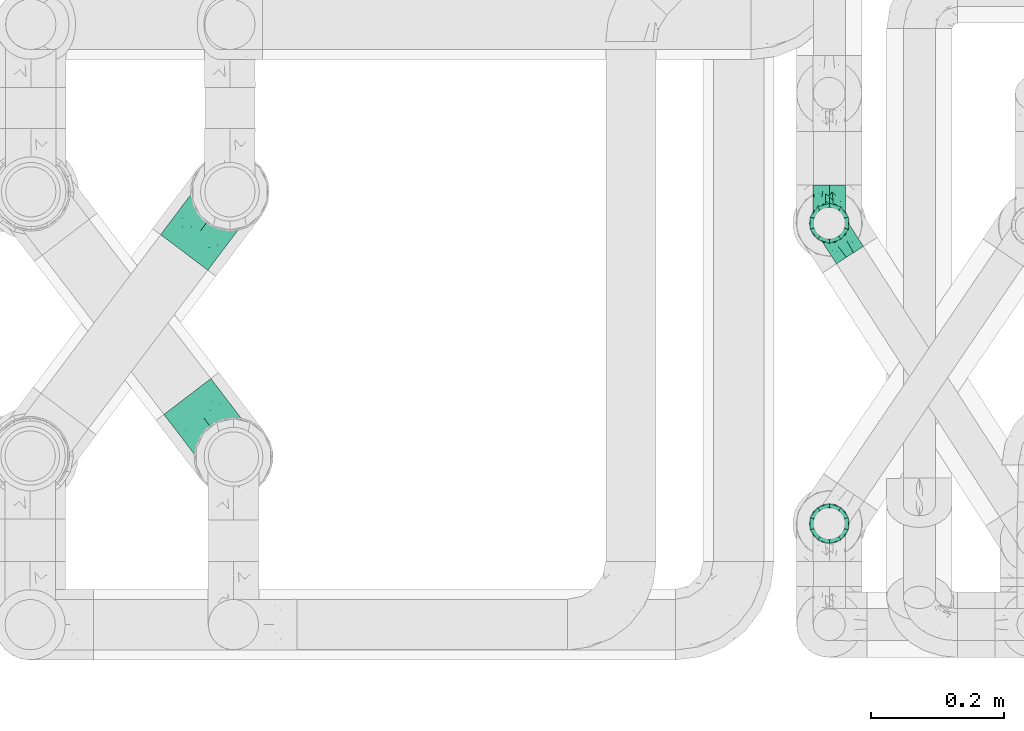
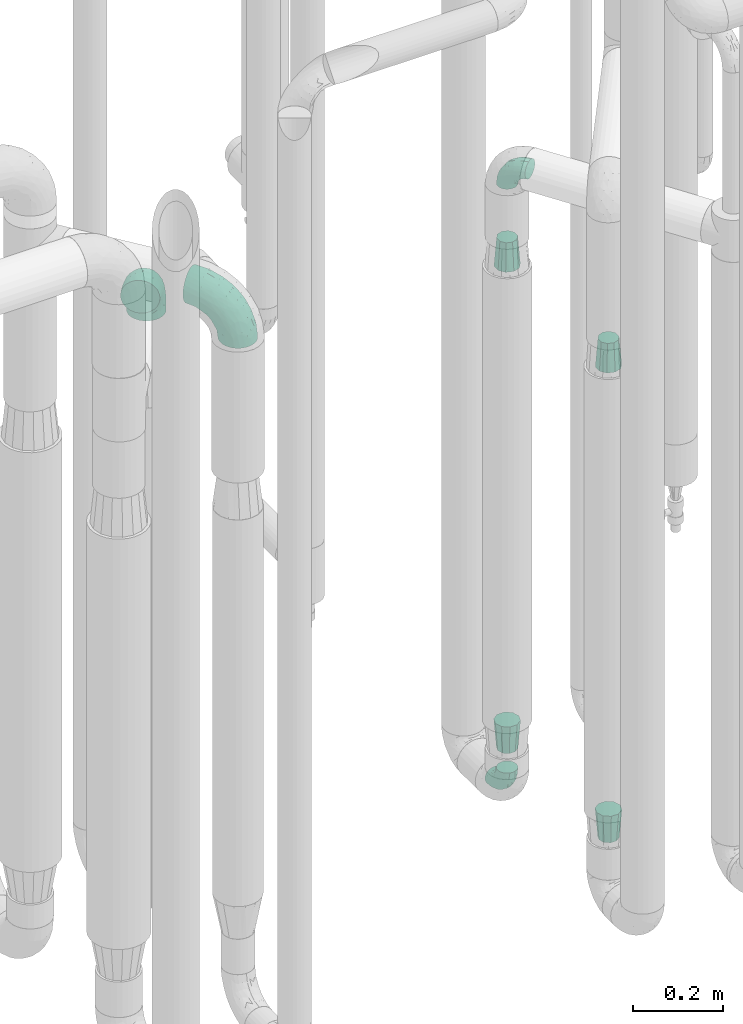
# One storey, part 661 of 827: 8 flow fittings.
"""IFC2X3 building model written with IfcOpenShell, lengths in millimetres."""

from ifc_helpers import new_model, entity, si_unit, converted_unit, derived_unit, direction, frame, origin, place, context, subcontext, project, spatial, faceted_brep, source, transform, mapped, material, type_object, type_shapes, element, save


model = new_model("IFC2X3")

# Units and contexts
model_context = context("Model", 3, precision=0.01, world=origin(), true_north=direction((6.12303176911189e-17, 1.0)))
body_context = subcontext(model_context, "Body", "Model", "MODEL_VIEW")
ifc_project = project(units=[si_unit("LENGTHUNIT", "METRE", prefix="MILLI"), si_unit("AREAUNIT", "SQUARE_METRE"), si_unit("VOLUMEUNIT", "CUBIC_METRE"), converted_unit("PLANEANGLEUNIT", "DEGREE", entity("IfcRatioMeasure", 0.0174532925199433), si_unit("PLANEANGLEUNIT", "RADIAN"), dimensions=[0, 0, 0, 0, 0, 0, 0]), si_unit("MASSUNIT", "GRAM", prefix="KILO"), derived_unit("MASSDENSITYUNIT", [(si_unit("MASSUNIT", "GRAM", prefix="KILO"), 1), (si_unit("LENGTHUNIT", "METRE"), -3)]), derived_unit("MOMENTOFINERTIAUNIT", [(si_unit("LENGTHUNIT", "METRE"), 4)]), si_unit("TIMEUNIT", "SECOND"), si_unit("FREQUENCYUNIT", "HERTZ"), si_unit("THERMODYNAMICTEMPERATUREUNIT", "DEGREE_CELSIUS"), derived_unit("THERMALTRANSMITTANCEUNIT", [(si_unit("MASSUNIT", "GRAM", prefix="KILO"), 1), (si_unit("THERMODYNAMICTEMPERATUREUNIT", "KELVIN"), -1), (si_unit("TIMEUNIT", "SECOND"), -3)]), derived_unit("VOLUMETRICFLOWRATEUNIT", [(si_unit("LENGTHUNIT", "METRE"), 3), (si_unit("TIMEUNIT", "SECOND"), -1)]), derived_unit("MASSFLOWRATEUNIT", [(si_unit("MASSUNIT", "GRAM", prefix="KILO"), 1), (si_unit("TIMEUNIT", "SECOND"), -1)]), derived_unit("ROTATIONALFREQUENCYUNIT", [(si_unit("TIMEUNIT", "SECOND"), -1)]), si_unit("ELECTRICCURRENTUNIT", "AMPERE"), si_unit("ELECTRICVOLTAGEUNIT", "VOLT"), si_unit("POWERUNIT", "WATT"), si_unit("FORCEUNIT", "NEWTON", prefix="KILO"), si_unit("ILLUMINANCEUNIT", "LUX"), si_unit("LUMINOUSFLUXUNIT", "LUMEN"), si_unit("LUMINOUSINTENSITYUNIT", "CANDELA"), derived_unit("USERDEFINED", [(si_unit("MASSUNIT", "GRAM", prefix="KILO"), -1), (si_unit("LENGTHUNIT", "METRE"), -2), (si_unit("TIMEUNIT", "SECOND"), 3), (si_unit("LUMINOUSFLUXUNIT", "LUMEN"), 1)]), derived_unit("LINEARVELOCITYUNIT", [(si_unit("LENGTHUNIT", "METRE"), 1), (si_unit("TIMEUNIT", "SECOND"), -1)]), si_unit("PRESSUREUNIT", "PASCAL"), derived_unit("USERDEFINED", [(si_unit("LENGTHUNIT", "METRE"), -2), (si_unit("MASSUNIT", "GRAM", prefix="KILO"), 1), (si_unit("TIMEUNIT", "SECOND"), -2)]), derived_unit("LINEARFORCEUNIT", [(si_unit("MASSUNIT", "GRAM", prefix="KILO"), 1), (si_unit("LENGTHUNIT", "METRE"), 1), (si_unit("TIMEUNIT", "SECOND"), -2), (si_unit("LENGTHUNIT", "METRE"), -1)]), derived_unit("PLANARFORCEUNIT", [(si_unit("MASSUNIT", "GRAM", prefix="KILO"), 1), (si_unit("LENGTHUNIT", "METRE"), 1), (si_unit("TIMEUNIT", "SECOND"), -2), (si_unit("LENGTHUNIT", "METRE"), -2)])], contexts=[model_context])

# Site, building, storey
site_placement = place(None, origin())
site = spatial("IfcSite", under=ifc_project, at=site_placement, CompositionType="ELEMENT")
building_placement = place(site_placement, origin())
building = spatial("IfcBuilding", under=site, at=building_placement, CompositionType="ELEMENT")
storey_placement = place(building_placement, frame((0.0, 0.0, 28200.0)))
storey = spatial("IfcBuildingStorey", under=building, at=storey_placement, Name="08", CompositionType="ELEMENT", Elevation=28200.0)

# Flow fittings
ifc_material = material()
pipe_fitting_type_1 = type_object("IfcPipeFittingType", Name="ADSK_1", PredefinedType="NOTDEFINED", material=ifc_material)
shared_shape_1 = source(origin(), body_context, "Body", "Brep", [
    faceted_brep([(-57.0, 12.07, -20.91), (-57.0, 6.25, -23.33), (-57.0, 0.0, -24.15), (-57.0, -6.25, -23.33), (-57.0, -12.08, -20.91), (-57.0, -17.08, -17.08), (-57.0, -20.91, -12.08), (-57.0, -23.33, -6.25), (-57.0, -24.15, 0.0), (-57.0, -23.33, 6.25), (-57.0, -20.91, 12.07), (-57.0, -17.08, 17.08), (-57.0, -12.08, 20.91), (-57.0, -6.25, 23.33), (-57.0, 0.0, 24.15), (-57.0, 6.25, 23.33), (-57.0, 12.07, 20.91), (-57.0, 17.08, 17.08), (-57.0, 20.91, 12.07), (-57.0, 23.33, 6.25), (-57.0, 24.15, 0.0), (-57.0, 23.33, -6.25), (-57.0, 20.91, -12.08), (-57.0, 17.08, -17.08), (0.0, 57.0, -24.15), (-6.25, 57.0, -23.33), (-12.07, 57.0, -20.91), (-17.08, 57.0, -17.08), (-20.91, 57.0, -12.08), (-23.33, 57.0, -6.25), (-24.15, 57.0, 0.0), (-23.33, 57.0, 6.25), (-20.91, 57.0, 12.07), (-17.08, 57.0, 17.08), (-12.07, 57.0, 20.91), (-6.25, 57.0, 23.33), (0.0, 57.0, 24.15), (6.25, 57.0, 23.33), (12.08, 57.0, 20.91), (17.08, 57.0, 17.08), (20.91, 57.0, 12.07), (23.33, 57.0, 6.25), (24.15, 57.0, 0.0), (23.33, 57.0, -6.25), (20.91, 57.0, -12.08), (17.08, 57.0, -17.08), (12.08, 57.0, -20.91), (6.25, 57.0, -23.33), (14.9, 21.14, 6.17), (13.61, 24.64, 12.48), (6.23, 8.95, 8.98), (-41.47, -21.06, 0.0), (-41.92, -18.38, 13.72), (-24.64, -13.61, 12.48), (-37.37, -13.24, 18.15), (-6.8, -4.93, 8.18), (-21.76, -15.19, 6.22), (-12.78, -9.18, 0.0), (-37.73, -20.51, 7.75), (-7.38, 7.38, 20.24), (-23.37, -4.26, 20.42), (-11.9, -3.19, 15.86), (-42.14, -8.7, 21.82), (13.24, 37.37, 18.15), (9.33, 23.53, 16.85), (4.26, 23.37, 20.42), (2.77, 10.92, 15.55), (-29.46, 0.91, 23.52), (-44.13, 20.56, 15.69), (-39.25, 26.33, 10.88), (-49.02, 22.92, 9.96), (-34.58, 23.87, 17.15), (-15.8, 6.8, 22.81), (-8.67, 20.47, 23.88), (-18.12, 12.9, 24.08), (-48.29, 14.92, 19.65), (-44.06, -2.85, 23.78), (-9.23, 48.95, 22.58), (-3.78, 42.74, 24.07), (-40.34, 4.26, 24.09), (-44.02, 26.14, 5.46), (-44.04, 9.88, 22.74), (-4.95, 16.87, 22.52), (-2.75, 1.43, 12.5), (-25.48, 40.98, 10.71), (20.51, 37.73, 7.75), (18.38, 41.92, 13.72), (8.7, 42.14, 21.82), (-25.95, -17.97, 0.0), (2.85, 44.06, 23.78), (21.06, 41.47, 0.0), (17.97, 25.95, 0.0), (-24.04, -9.27, 17.13), (-33.26, 33.26, 5.86), (-28.55, 40.57, 0.0), (-40.57, 28.55, 0.0), (-25.29, 47.19, 4.06), (-27.01, 31.1, 16.77), (-15.7, 43.95, 19.9), (-20.27, 45.22, 15.61), (-30.53, 31.98, 12.64), (-11.28, 38.33, 22.92), (-9.97, 27.88, 24.09), (-20.15, 30.26, 21.25), (-31.25, 11.75, 23.64), (-28.75, 7.23, 24.15), (-29.53, 18.06, 22.27), (-28.44, 24.21, 20.02), (-37.55, 17.7, 20.26), (-15.88, 29.25, 22.99), (-20.82, 20.82, 23.44), (-0.91, 29.46, 23.52), (-13.5, -7.67, 12.04), (1.49, 1.56, 5.16), (8.86, 10.35, 4.59), (0.38, -0.38, 0.0), (9.18, 12.78, 0.0), (-37.37, -13.24, -18.15), (8.86, 10.35, -4.59), (-45.22, 20.27, -15.61), (-43.95, 15.7, -19.9), (-38.33, 11.28, -22.92), (-48.95, 9.23, -22.58), (-47.19, 25.29, -4.06), (-33.26, 33.26, -5.86), (18.38, 41.92, -13.72), (-30.26, 20.15, -21.25), (2.85, 44.06, -23.78), (-4.26, 40.34, -24.09), (-40.98, 25.48, -10.71), (-41.92, -18.38, -13.72), (9.25, 23.5, -16.92), (4.26, 23.37, -20.42), (13.24, 37.37, -18.15), (-37.73, -20.51, -7.75), (-11.75, 31.25, -23.64), (-7.23, 28.75, -24.15), (-12.9, 18.12, -24.08), (8.7, 42.14, -21.82), (-44.06, -2.85, -23.78), (-6.8, 15.8, -22.81), (-20.47, 8.67, -23.88), (-24.64, -13.61, -12.48), (-42.74, 3.78, -24.07), (-18.06, 29.53, -22.27), (-24.21, 28.44, -20.02), (-27.88, 9.97, -24.09), (-31.1, 27.01, -16.77), (-26.14, 44.02, -5.46), (14.9, 21.14, -6.17), (20.51, 37.73, -7.75), (-9.88, 44.04, -22.74), (-20.56, 44.13, -15.69), (-21.76, -15.19, -6.22), (-13.5, -7.67, -12.04), (-24.14, -9.76, -16.74), (-11.9, -3.19, -15.86), (-14.92, 48.29, -19.65), (-23.37, -4.26, -20.42), (-0.91, 29.46, -23.52), (-26.33, 39.25, -10.88), (-23.87, 34.58, -17.15), (-42.14, -8.7, -21.82), (-22.92, 49.02, -9.96), (13.61, 24.64, -12.48), (-31.98, 30.53, -12.64), (-16.87, 4.95, -22.52), (-17.7, 37.55, -20.26), (-29.25, 15.88, -22.99), (-20.82, 20.82, -23.44), (-29.46, 0.91, -23.52), (-7.38, 7.38, -20.24), (2.77, 10.92, -15.55), (6.23, 8.95, -8.98), (-6.8, -4.93, -8.18), (-2.81, 1.41, -12.54), (1.49, 1.56, -5.16)], [[[0, 1, 2, 3, 4, 5, 6, 7, 8, 9, 10, 11, 12, 13, 14, 15, 16, 17, 18, 19, 20, 21, 22, 23]], [[24, 25, 26, 27, 28, 29, 30, 31, 32, 33, 34, 35, 36, 37, 38, 39, 40, 41, 42, 43, 44, 45, 46, 47]], [[48, 49, 50]], [[9, 8, 51]], [[52, 53, 54]], [[55, 56, 57]], [[10, 58, 52]], [[9, 58, 10]], [[59, 60, 61]], [[54, 12, 11]], [[54, 62, 12]], [[63, 39, 38]], [[64, 65, 66]], [[62, 60, 67]], [[68, 69, 70]], [[71, 69, 68]], [[72, 73, 74]], [[16, 75, 17]], [[13, 76, 14]], [[35, 77, 78]], [[14, 79, 15]], [[17, 68, 18]], [[14, 76, 79]], [[20, 19, 80]], [[70, 19, 18]], [[81, 15, 79]], [[15, 81, 16]], [[73, 72, 82]], [[66, 83, 50]], [[32, 31, 84]], [[85, 86, 49]], [[63, 87, 65]], [[56, 58, 88]], [[36, 89, 37]], [[85, 41, 40]], [[36, 35, 78]], [[90, 41, 85]], [[40, 39, 86]], [[12, 62, 13]], [[86, 85, 40]], [[48, 85, 49]], [[85, 91, 90]], [[87, 38, 37]], [[92, 60, 54]], [[80, 69, 93]], [[93, 94, 95]], [[10, 52, 11]], [[94, 96, 30]], [[97, 98, 99]], [[80, 93, 95]], [[100, 97, 84]], [[99, 98, 33]], [[101, 102, 78]], [[103, 101, 98]], [[96, 31, 30]], [[77, 98, 101]], [[77, 35, 34]], [[34, 33, 98]], [[9, 51, 58]], [[87, 63, 38]], [[104, 105, 74]], [[106, 103, 107]], [[106, 81, 104]], [[75, 68, 17]], [[108, 107, 71]], [[33, 32, 99]], [[109, 103, 110]], [[101, 109, 102]], [[89, 78, 111]], [[53, 52, 58]], [[54, 11, 52]], [[60, 62, 54]], [[88, 58, 51]], [[76, 62, 67]], [[53, 112, 92]], [[60, 59, 72]], [[39, 63, 86]], [[49, 86, 63]], [[89, 87, 37]], [[42, 41, 90]], [[111, 82, 65]], [[111, 65, 87]], [[65, 59, 66]], [[104, 81, 79]], [[75, 81, 108]], [[32, 84, 99]], [[97, 99, 84]], [[98, 97, 103]], [[106, 107, 108]], [[74, 102, 110]], [[111, 78, 102]], [[74, 110, 104]], [[74, 67, 72]], [[61, 92, 112]], [[66, 59, 61]], [[56, 53, 58]], [[66, 50, 49]], [[61, 112, 83]], [[66, 49, 64]], [[78, 89, 36]], [[87, 89, 111]], [[62, 76, 13]], [[79, 76, 67]], [[100, 93, 69]], [[96, 93, 84]], [[55, 113, 50]], [[113, 114, 50]], [[104, 79, 105]], [[106, 104, 110]], [[20, 80, 95]], [[85, 48, 91]], [[115, 114, 113]], [[116, 91, 48]], [[70, 80, 19]], [[93, 96, 94]], [[84, 31, 96]], [[103, 106, 110]], [[81, 106, 108]], [[103, 97, 107]], [[71, 107, 97]], [[71, 97, 100]], [[108, 71, 68]], [[79, 67, 105]], [[67, 74, 105]], [[115, 113, 57]], [[112, 56, 55]], [[56, 88, 57]], [[60, 72, 67]], [[82, 72, 59]], [[65, 82, 59]], [[82, 111, 73]], [[111, 102, 73]], [[102, 74, 73]], [[81, 75, 16]], [[68, 75, 108]], [[68, 70, 18]], [[80, 70, 69]], [[98, 77, 34]], [[78, 77, 101]], [[93, 100, 84]], [[71, 100, 69]], [[102, 109, 110]], [[101, 103, 109]], [[53, 92, 54]], [[61, 60, 92]], [[56, 112, 53]], [[83, 112, 55]], [[50, 83, 55]], [[61, 83, 66]], [[49, 63, 64]], [[65, 64, 63]], [[57, 113, 55]], [[114, 115, 116]], [[116, 48, 114]], [[48, 50, 114]], [[117, 5, 4]], [[116, 115, 118]], [[119, 120, 23]], [[121, 122, 120]], [[95, 123, 20]], [[0, 23, 120]], [[124, 95, 94]], [[125, 45, 44]], [[121, 120, 126]], [[24, 127, 128]], [[22, 21, 129]], [[0, 122, 1]], [[5, 117, 130]], [[131, 132, 133]], [[134, 88, 51]], [[135, 136, 137]], [[6, 5, 130]], [[46, 138, 47]], [[139, 3, 2]], [[140, 141, 137]], [[6, 134, 7]], [[134, 130, 142]], [[143, 2, 1]], [[144, 126, 145]], [[121, 146, 143]], [[147, 120, 119]], [[94, 148, 124]], [[149, 150, 91]], [[30, 29, 148]], [[151, 25, 128]], [[27, 152, 28]], [[134, 153, 88]], [[154, 155, 156]], [[27, 26, 157]], [[151, 26, 25]], [[155, 158, 156]], [[24, 47, 127]], [[1, 122, 143]], [[138, 132, 159]], [[160, 152, 161]], [[24, 128, 25]], [[46, 133, 138]], [[162, 117, 4]], [[148, 160, 124]], [[152, 160, 163]], [[154, 142, 155]], [[45, 125, 133]], [[133, 46, 45]], [[125, 164, 133]], [[51, 7, 134]], [[42, 90, 43]], [[165, 147, 129]], [[153, 134, 142]], [[43, 150, 44]], [[162, 4, 3]], [[141, 140, 166]], [[117, 162, 158]], [[163, 29, 28]], [[43, 90, 150]], [[123, 21, 20]], [[144, 151, 135]], [[157, 152, 27]], [[167, 145, 161]], [[23, 22, 119]], [[168, 126, 169]], [[121, 168, 146]], [[139, 143, 170]], [[142, 130, 117]], [[8, 7, 51]], [[134, 6, 130]], [[139, 162, 3]], [[170, 166, 158]], [[170, 158, 162]], [[158, 171, 156]], [[44, 150, 125]], [[91, 150, 90]], [[164, 125, 150]], [[132, 138, 133]], [[127, 138, 159]], [[131, 164, 172]], [[132, 171, 140]], [[135, 151, 128]], [[157, 151, 167]], [[22, 129, 119]], [[147, 119, 129]], [[120, 147, 126]], [[144, 145, 167]], [[137, 146, 169]], [[170, 143, 146]], [[137, 169, 135]], [[137, 159, 140]], [[171, 172, 156]], [[173, 174, 175]], [[156, 175, 154]], [[174, 57, 153]], [[132, 172, 171]], [[172, 164, 173]], [[143, 139, 2]], [[162, 139, 170]], [[138, 127, 47]], [[128, 127, 159]], [[165, 124, 160]], [[123, 124, 129]], [[149, 173, 164]], [[176, 174, 173]], [[135, 128, 136]], [[144, 135, 169]], [[150, 149, 164]], [[176, 118, 115]], [[149, 91, 116]], [[30, 148, 94]], [[163, 148, 29]], [[124, 123, 95]], [[129, 21, 123]], [[126, 144, 169]], [[151, 144, 167]], [[126, 147, 145]], [[161, 145, 147]], [[161, 147, 165]], [[167, 161, 152]], [[128, 159, 136]], [[159, 137, 136]], [[154, 153, 142]], [[132, 140, 159]], [[174, 176, 57]], [[57, 88, 153]], [[166, 140, 171]], [[158, 166, 171]], [[166, 170, 141]], [[170, 146, 141]], [[146, 137, 141]], [[151, 157, 26]], [[152, 157, 167]], [[152, 163, 28]], [[148, 163, 160]], [[120, 122, 0]], [[143, 122, 121]], [[124, 165, 129]], [[161, 165, 160]], [[146, 168, 169]], [[121, 126, 168]], [[142, 117, 155]], [[158, 155, 117]], [[175, 156, 172]], [[153, 154, 174]], [[173, 175, 172]], [[174, 154, 175]], [[164, 131, 133]], [[172, 132, 131]], [[176, 173, 118]], [[57, 176, 115]], [[173, 149, 118]], [[149, 116, 118]]]),
])
type_shapes(pipe_fitting_type_1, [shared_shape_1])
for number, where, z_axis, x_axis, name in (
    (1, (46692.79, 14239.53, 2100.11), (0.839206573460925, 0.543812768386302, 0.0), (0.0, 0.0, 1.0), "ADSK_1"),
    (2, (46692.79, 14239.53, 400.0), (-1.0, 0.0, 0.0), (0.0, -1.0, 0.0), "ADSK_1"),
):
    element("IfcFlowFitting", number, at=place(storey_placement, frame(where, z_axis=z_axis, x_axis=x_axis)), inside=storey, type_object=pipe_fitting_type_1, material=ifc_material, Name=name, ObjectType="ADSK_1", context=body_context, shape_type="MappedRepresentation", body=[
        mapped(shared_shape_1, transform((0.0, 0.0, 0.0), scale=1.0)),
    ])
pipe_fitting_type_2 = type_object("IfcPipeFittingType", Name="ADSK_1", PredefinedType="NOTDEFINED", material=ifc_material)
shared_shape_2 = source(origin(), body_context, "Body", "Brep", [
    faceted_brep([(-114.0, 22.22, -38.49), (-114.0, 11.5, -42.94), (-114.0, 0.0, -44.45), (-114.0, -11.5, -42.94), (-114.0, -22.23, -38.49), (-114.0, -31.43, -31.43), (-114.0, -38.49, -22.23), (-114.0, -42.94, -11.5), (-114.0, -44.45, 0.0), (-114.0, -42.94, 11.5), (-114.0, -38.49, 22.22), (-114.0, -31.43, 31.43), (-114.0, -22.23, 38.49), (-114.0, -11.5, 42.94), (-114.0, 0.0, 44.45), (-114.0, 11.5, 42.94), (-114.0, 22.22, 38.49), (-114.0, 31.43, 31.43), (-114.0, 38.49, 22.22), (-114.0, 42.94, 11.5), (-114.0, 44.45, 0.0), (-114.0, 42.94, -11.5), (-114.0, 38.49, -22.23), (-114.0, 31.43, -31.43), (0.0, 114.0, -44.45), (-11.5, 114.0, -42.94), (-22.22, 114.0, -38.49), (-31.43, 114.0, -31.43), (-38.49, 114.0, -22.23), (-42.94, 114.0, -11.5), (-44.45, 114.0, 0.0), (-42.94, 114.0, 11.5), (-38.49, 114.0, 22.22), (-31.43, 114.0, 31.43), (-22.22, 114.0, 38.49), (-11.5, 114.0, 42.94), (0.0, 114.0, 44.45), (11.5, 114.0, 42.94), (22.23, 114.0, 38.49), (31.43, 114.0, 31.43), (38.49, 114.0, 22.22), (42.94, 114.0, 11.5), (44.45, 114.0, 0.0), (42.94, 114.0, -11.5), (38.49, 114.0, -22.23), (31.43, 114.0, -31.43), (22.23, 114.0, -38.49), (11.5, 114.0, -42.94), (-24.5, -15.82, 8.24), (-7.18, -2.06, 7.97), (-13.53, -4.79, 15.72), (-92.03, -41.56, 0.0), (-77.08, -37.56, 14.57), (23.74, 74.96, 33.55), (-72.99, -39.05, 0.0), (-84.56, -15.6, 40.23), (-47.88, -6.37, 37.83), (-59.8, 2.77, 43.37), (-84.46, -33.54, 25.41), (16.69, 49.28, 31.02), (6.37, 47.88, 37.83), (3.35, 25.47, 29.77), (-47.43, 81.55, 19.51), (-74.96, -23.74, 33.55), (-46.77, -27.89, 11.23), (-53.88, -31.14, 0.0), (-87.05, 38.52, 28.81), (-63.44, 55.78, 24.79), (-93.24, 43.37, 18.58), (-16.67, 16.67, 37.64), (-25.47, -3.35, 29.77), (-17.2, 97.7, 41.53), (-7.42, 85.54, 44.3), (-67.09, 46.29, 31.23), (-18.08, 42.1, 44.06), (-32.93, 14.9, 42.17), (-11.54, 34.94, 41.69), (-95.7, 27.79, 36.14), (-88.55, -4.92, 43.79), (-2.77, 59.8, 43.37), (-87.65, 48.44, 9.87), (-81.01, 8.37, 44.32), (-37.63, 90.26, 28.6), (-51.29, 61.56, 30.59), (-29.32, 87.72, 36.52), (23.49, 49.5, 23.28), (8.19, 20.11, 19.18), (-70.06, 58.9, 9.01), (-87.38, 49.74, 0.0), (-88.15, 18.57, 41.8), (-7.96, 6.22, 24.33), (33.54, 84.46, 25.41), (37.56, 77.08, 14.57), (-58.37, 34.98, 40.92), (-62.38, 23.02, 43.45), (24.15, 39.93, 12.16), (31.14, 53.88, 0.0), (-58.13, 14.61, 44.45), (-37.17, 26.09, 44.37), (4.92, 88.55, 43.79), (-34.77, -23.22, 0.0), (-49.5, -23.49, 23.28), (41.56, 92.03, 0.0), (-57.83, 66.03, 19.12), (-71.84, 54.46, 17.06), (-46.46, 94.23, 8.51), (-49.74, 87.38, 0.0), (-38.96, 59.98, 38.88), (-55.29, 46.95, 36.83), (-64.82, 64.82, 0.0), (-55.88, 73.75, 10.01), (15.6, 84.56, 40.23), (-21.6, 76.38, 42.11), (-49.04, -15.53, 31.95), (-19.97, 55.59, 44.33), (-73.61, 33.95, 37.2), (-31.05, 58.14, 42.19), (-41.3, 41.3, 43.02), (-27.36, -11.22, 22.61), (9.28, 15.84, 8.73), (23.22, 34.77, 0.0), (39.05, 72.99, 0.0), (-1.96, 1.96, 0.0), (10.63, 18.37, 0.0), (-18.37, -10.63, 0.0), (-97.7, 17.2, -41.53), (9.28, 15.84, -8.73), (-13.53, -4.79, -15.72), (8.19, 20.11, -19.18), (-85.54, 7.42, -44.3), (-8.37, 81.01, -44.32), (-90.26, 37.63, -28.6), (-87.72, 29.32, -36.52), (-27.79, 95.7, -36.14), (-38.52, 87.05, -28.81), (-94.23, 46.46, -8.51), (-84.56, -15.6, -40.23), (-73.75, 55.88, -10.01), (-10.19, -4.86, -7.51), (-76.38, 21.6, -42.11), (-59.98, 38.96, -38.88), (-49.28, -16.69, -31.02), (-47.88, -6.37, -37.83), (-25.47, -3.35, -29.77), (-34.98, 58.37, -40.92), (-46.95, 55.29, -36.83), (-77.08, -37.56, -14.57), (-18.57, 88.15, -41.8), (-23.02, 62.38, -43.45), (-55.78, 63.44, -24.79), (-43.37, 93.24, -18.58), (-84.46, -33.54, -25.41), (-33.95, 73.61, -37.2), (-46.29, 67.09, -31.23), (-74.96, -23.74, -33.55), (-48.44, 87.65, -9.87), (-45.44, -27.06, -11.87), (-88.55, -4.92, -43.79), (-49.5, -23.49, -23.28), (-14.61, 58.13, -44.45), (-26.09, 37.17, -44.37), (15.6, 84.56, -40.23), (6.37, 47.88, -37.83), (-2.77, 59.8, -43.37), (-81.55, 47.43, -19.51), (33.54, 84.46, -25.41), (23.49, 49.5, -23.28), (23.74, 74.96, -33.55), (-42.1, 18.08, -44.06), (-14.9, 32.93, -42.17), (-34.94, 11.54, -41.69), (-61.56, 51.29, -30.59), (-27.36, -11.22, -22.61), (37.56, 77.08, -14.57), (4.92, 88.55, -43.79), (-59.8, 2.77, -43.37), (-66.03, 57.83, -19.12), (-54.46, 71.84, -17.06), (-55.59, 19.97, -44.33), (-58.9, 70.06, -9.01), (24.15, 39.93, -12.16), (15.53, 49.04, -31.95), (-58.14, 31.05, -42.19), (-41.3, 41.3, -43.02), (-16.67, 16.67, -37.64), (3.35, 25.47, -29.77), (-7.96, 6.22, -24.33), (-26.36, -16.33, -11.05)], [[[0, 1, 2, 3, 4, 5, 6, 7, 8, 9, 10, 11, 12, 13, 14, 15, 16, 17, 18, 19, 20, 21, 22, 23]], [[24, 25, 26, 27, 28, 29, 30, 31, 32, 33, 34, 35, 36, 37, 38, 39, 40, 41, 42, 43, 44, 45, 46, 47]], [[48, 49, 50]], [[51, 52, 9]], [[53, 39, 38]], [[9, 52, 10]], [[54, 52, 51]], [[55, 56, 57]], [[11, 10, 58]], [[59, 60, 61]], [[32, 31, 62]], [[63, 12, 11]], [[63, 55, 12]], [[64, 52, 65]], [[66, 67, 68]], [[69, 56, 70]], [[35, 71, 72]], [[67, 66, 73]], [[74, 75, 76]], [[16, 77, 17]], [[13, 78, 14]], [[76, 79, 74]], [[68, 80, 19]], [[18, 17, 66]], [[14, 78, 81]], [[20, 19, 80]], [[82, 83, 84]], [[85, 61, 86]], [[87, 88, 80]], [[18, 68, 19]], [[15, 89, 16]], [[14, 81, 15]], [[70, 90, 61]], [[17, 77, 66]], [[91, 85, 92]], [[93, 89, 94]], [[95, 96, 92]], [[84, 71, 34]], [[94, 97, 98]], [[37, 36, 99]], [[40, 39, 91]], [[40, 92, 41]], [[65, 100, 64]], [[91, 92, 40]], [[58, 101, 63]], [[92, 102, 41]], [[92, 85, 95]], [[67, 103, 104]], [[34, 33, 84]], [[105, 62, 31]], [[52, 58, 10]], [[106, 105, 30]], [[93, 107, 108]], [[106, 109, 110]], [[53, 111, 60]], [[84, 112, 71]], [[84, 107, 112]], [[33, 82, 84]], [[12, 55, 13]], [[113, 56, 63]], [[111, 38, 37]], [[34, 71, 35]], [[36, 35, 72]], [[112, 114, 72]], [[110, 105, 106]], [[111, 53, 38]], [[115, 108, 73]], [[89, 15, 81]], [[104, 87, 80]], [[110, 87, 103]], [[33, 32, 82]], [[116, 107, 117]], [[112, 116, 114]], [[99, 72, 79]], [[56, 55, 63]], [[78, 55, 57]], [[101, 118, 113]], [[56, 69, 75]], [[99, 111, 37]], [[79, 76, 60]], [[79, 60, 111]], [[60, 69, 61]], [[101, 58, 52]], [[63, 11, 58]], [[39, 53, 91]], [[85, 91, 53]], [[94, 89, 81]], [[77, 89, 115]], [[84, 83, 107]], [[93, 108, 115]], [[98, 114, 117]], [[79, 72, 114]], [[98, 117, 94]], [[98, 57, 75]], [[32, 62, 82]], [[83, 82, 62]], [[70, 113, 118]], [[61, 85, 59]], [[48, 64, 100]], [[95, 119, 120]], [[69, 70, 61]], [[70, 118, 90]], [[72, 99, 36]], [[111, 99, 79]], [[55, 78, 13]], [[81, 78, 57]], [[94, 81, 97]], [[93, 94, 117]], [[66, 68, 18]], [[80, 68, 104]], [[103, 87, 104]], [[80, 88, 20]], [[50, 49, 119]], [[95, 85, 86]], [[119, 95, 86]], [[121, 92, 96]], [[50, 119, 86]], [[119, 122, 123, 120]], [[110, 109, 87]], [[88, 87, 109]], [[62, 105, 110]], [[30, 105, 31]], [[81, 57, 97]], [[57, 98, 97]], [[107, 93, 117]], [[89, 93, 115]], [[107, 83, 108]], [[73, 108, 83]], [[67, 73, 83]], [[115, 73, 66]], [[103, 83, 62]], [[67, 104, 68]], [[83, 103, 67]], [[110, 103, 62]], [[89, 77, 16]], [[66, 77, 115]], [[56, 75, 57]], [[76, 75, 69]], [[60, 76, 69]], [[79, 114, 74]], [[114, 98, 74]], [[75, 74, 98]], [[9, 8, 51]], [[102, 92, 121]], [[102, 42, 41]], [[72, 71, 112]], [[52, 54, 65]], [[64, 48, 118]], [[101, 52, 64]], [[124, 122, 49]], [[118, 48, 50]], [[49, 48, 124]], [[119, 49, 122]], [[48, 100, 124]], [[114, 116, 117]], [[112, 107, 116]], [[101, 113, 63]], [[70, 56, 113]], [[64, 118, 101]], [[90, 50, 86]], [[50, 90, 118]], [[61, 90, 86]], [[85, 53, 59]], [[60, 59, 53]], [[95, 120, 96]], [[125, 1, 0]], [[126, 127, 128]], [[2, 1, 129]], [[24, 130, 25]], [[131, 132, 23]], [[27, 133, 134]], [[88, 135, 20]], [[136, 4, 3]], [[88, 109, 137]], [[138, 122, 124]], [[139, 132, 140]], [[141, 142, 143]], [[144, 140, 145]], [[125, 132, 139]], [[6, 146, 7]], [[144, 147, 148]], [[146, 51, 7]], [[134, 149, 150]], [[146, 6, 151]], [[152, 145, 153]], [[154, 4, 136]], [[154, 136, 142]], [[150, 155, 29]], [[43, 42, 102]], [[65, 146, 156]], [[0, 23, 132]], [[157, 3, 2]], [[146, 151, 158]], [[148, 159, 160]], [[161, 162, 163]], [[135, 164, 21]], [[165, 166, 167]], [[168, 169, 170]], [[147, 25, 130]], [[171, 132, 131]], [[155, 30, 29]], [[172, 141, 143]], [[134, 28, 27]], [[149, 134, 153]], [[173, 165, 44]], [[26, 25, 147]], [[22, 21, 164]], [[24, 174, 130]], [[133, 27, 26]], [[170, 175, 168]], [[24, 47, 174]], [[45, 167, 46]], [[28, 150, 29]], [[1, 125, 129]], [[156, 100, 65]], [[165, 45, 44]], [[161, 46, 167]], [[173, 44, 43]], [[6, 5, 151]], [[173, 102, 121]], [[137, 135, 88]], [[46, 161, 47]], [[102, 173, 43]], [[149, 176, 177]], [[172, 158, 141]], [[139, 178, 129]], [[154, 5, 4]], [[156, 146, 158]], [[106, 155, 179]], [[173, 96, 180]], [[181, 162, 167]], [[177, 179, 155]], [[137, 179, 176]], [[23, 22, 131]], [[182, 140, 183]], [[139, 182, 178]], [[157, 129, 175]], [[157, 136, 3]], [[175, 170, 142]], [[175, 142, 136]], [[142, 184, 143]], [[162, 161, 167]], [[174, 161, 163]], [[181, 166, 185]], [[162, 184, 169]], [[5, 154, 151]], [[158, 151, 154]], [[166, 165, 173]], [[167, 45, 165]], [[148, 147, 130]], [[133, 147, 152]], [[132, 171, 140]], [[144, 145, 152]], [[160, 178, 183]], [[175, 129, 178]], [[160, 183, 148]], [[160, 163, 169]], [[22, 164, 131]], [[171, 131, 164]], [[162, 185, 184]], [[186, 127, 172]], [[185, 128, 186]], [[156, 187, 100]], [[185, 166, 128]], [[143, 184, 185]], [[129, 157, 2]], [[136, 157, 175]], [[161, 174, 47]], [[130, 174, 163]], [[148, 130, 159]], [[144, 148, 183]], [[134, 150, 28]], [[155, 150, 177]], [[176, 179, 177]], [[155, 106, 30]], [[166, 180, 128]], [[128, 180, 126]], [[173, 180, 166]], [[126, 120, 123, 122]], [[120, 126, 180]], [[122, 138, 126]], [[137, 109, 179]], [[106, 179, 109]], [[164, 135, 137]], [[20, 135, 21]], [[130, 163, 159]], [[163, 160, 159]], [[140, 144, 183]], [[147, 144, 152]], [[140, 171, 145]], [[153, 145, 171]], [[149, 153, 171]], [[152, 153, 134]], [[176, 171, 164]], [[149, 177, 150]], [[171, 176, 149]], [[137, 176, 164]], [[147, 133, 26]], [[134, 133, 152]], [[162, 169, 163]], [[170, 169, 184]], [[142, 170, 184]], [[175, 178, 168]], [[178, 160, 168]], [[169, 168, 160]], [[51, 146, 54]], [[51, 8, 7]], [[132, 125, 0]], [[129, 125, 139]], [[156, 158, 172]], [[65, 54, 146]], [[178, 182, 183]], [[139, 140, 182]], [[158, 154, 141]], [[142, 141, 154]], [[186, 172, 143]], [[172, 127, 187]], [[185, 186, 143]], [[127, 186, 128]], [[187, 127, 138]], [[124, 100, 187]], [[126, 138, 127]], [[187, 138, 124]], [[172, 187, 156]], [[166, 181, 167]], [[185, 162, 181]], [[96, 173, 121]], [[96, 120, 180]]]),
])
type_shapes(pipe_fitting_type_2, [shared_shape_2])
for number, where, z_axis, x_axis, name in (
    (3, (45793.07, 14286.62, 2100.0), (0.798635510047293, -0.601815023152049, 0.0), (0.0, 0.0, 1.0), "ADSK_1"),
    (4, (45798.44, 13888.82, 2265.0), (-0.794341681216586, -0.607471228521984, 0.0), (0.0, 0.0, 1.0), "ADSK_1"),
):
    element("IfcFlowFitting", number, at=place(storey_placement, frame(where, z_axis=z_axis, x_axis=x_axis)), inside=storey, type_object=pipe_fitting_type_2, material=ifc_material, Name=name, ObjectType="ADSK_1", context=body_context, shape_type="MappedRepresentation", body=[
        mapped(shared_shape_2, transform((0.0, 0.0, 0.0), scale=1.0)),
    ])
pipe_fitting_type_3 = type_object("IfcPipeFittingType", Name="ADSK_1", PredefinedType="NOTDEFINED", material=ifc_material)
shared_shape_3 = source(origin(), body_context, "Body", "Brep", [
    faceted_brep([(76.0, 24.15, 0.0), (76.0, 21.84, 7.1), (76.0, 19.54, 14.2), (76.0, 13.5, 18.58), (76.0, 7.46, 22.97), (76.0, 0.0, 22.97), (76.0, -7.46, 22.97), (76.0, -13.5, 18.58), (76.0, -19.54, 14.2), (76.0, -21.84, 7.1), (76.0, -24.15, 0.0), (76.0, -21.84, -7.1), (76.0, -19.54, -14.2), (76.0, -13.5, -18.58), (76.0, -7.46, -22.97), (76.0, 0.0, -22.97), (76.0, 7.46, -22.97), (76.0, 13.5, -18.58), (76.0, 19.54, -14.2), (76.0, 21.84, -7.1), (0.0, -30.15, 0.0), (0.0, -27.27, 8.86), (0.0, -24.39, 17.72), (0.0, -16.85, 23.2), (0.0, -9.32, 28.67), (0.0, 0.0, 28.67), (0.0, 9.32, 28.67), (0.0, 16.85, 23.2), (0.0, 24.39, 17.72), (0.0, 26.33, 11.75), (0.0, 28.24, 5.87), (0.0, 30.15, 0.0), (0.0, 27.27, -8.86), (0.0, 24.39, -17.72), (0.0, 16.85, -23.2), (0.0, 9.32, -28.67), (0.0, 0.0, -28.67), (0.0, -9.32, -28.67), (0.0, -16.85, -23.2), (0.0, -24.39, -17.72), (0.0, -26.33, -11.75), (0.0, -28.24, -5.87)], [[[0, 1, 2, 3, 4, 5, 6, 7, 8, 9, 10, 11, 12, 13, 14, 15, 16, 17, 18, 19]], [[20, 21, 22, 23, 24, 25, 26, 27, 28, 29, 30, 31, 32, 33, 34, 35, 36, 37, 38, 39, 40, 41]], [[19, 18, 33, 32, 31, 0]], [[36, 35, 16, 15, 14, 37]], [[35, 34, 33, 18, 17, 16]], [[41, 40, 39, 12, 11, 10, 20]], [[14, 13, 12, 39, 38, 37]], [[9, 8, 22, 21, 20, 10]], [[25, 24, 6, 5, 4, 26]], [[24, 23, 22, 8, 7, 6]], [[30, 29, 28, 2, 1, 0, 31]], [[4, 3, 2, 28, 27, 26]]]),
])
type_shapes(pipe_fitting_type_3, [shared_shape_3])
for number, where, z_axis, x_axis, name in (
    (5, (46692.79, 14239.53, 1821.5), (1.0, 0.0, 0.0), (0.0, 0.0, 1.0), "ADSK_1"),
    (6, (46692.79, 13788.51, 1821.5), (1.0, 0.0, 0.0), (0.0, 0.0, 1.0), "ADSK_1"),
):
    element("IfcFlowFitting", number, at=place(storey_placement, frame(where, z_axis=z_axis, x_axis=x_axis)), inside=storey, type_object=pipe_fitting_type_3, material=ifc_material, Name=name, ObjectType="ADSK_1", context=body_context, shape_type="MappedRepresentation", body=[
        mapped(shared_shape_3, transform((0.0, 0.0, 0.0), scale=1.0)),
    ])
pipe_fitting_type_4 = type_object("IfcPipeFittingType", Name="ADSK_1", PredefinedType="NOTDEFINED", material=ifc_material)
shared_shape_4 = source(origin(), body_context, "Body", "Brep", [
    faceted_brep([(76.0, -30.15, 0.0), (76.0, -28.24, -5.87), (76.0, -26.33, -11.75), (76.0, -24.39, -17.72), (76.0, -16.85, -23.2), (76.0, -9.32, -28.67), (76.0, 0.0, -28.67), (76.0, 9.32, -28.67), (76.0, 16.85, -23.2), (76.0, 24.39, -17.72), (76.0, 26.33, -11.75), (76.0, 28.24, -5.87), (76.0, 30.15, 0.0), (76.0, 28.24, 5.87), (76.0, 26.33, 11.75), (76.0, 24.39, 17.72), (76.0, 16.85, 23.2), (76.0, 9.32, 28.67), (76.0, 0.0, 28.67), (76.0, -9.32, 28.67), (76.0, -16.85, 23.2), (76.0, -24.39, 17.72), (76.0, -26.33, 11.75), (76.0, -28.24, 5.87), (0.0, -19.54, -14.2), (0.0, -21.84, -7.1), (0.0, -24.15, 0.0), (0.0, -21.84, 7.1), (0.0, -19.54, 14.2), (0.0, -13.5, 18.58), (0.0, -7.46, 22.97), (0.0, 0.0, 22.97), (0.0, 7.46, 22.97), (0.0, 13.5, 18.58), (0.0, 19.54, 14.2), (0.0, 21.84, 7.1), (0.0, 24.15, 0.0), (0.0, 21.84, -7.1), (0.0, 19.54, -14.2), (0.0, 13.5, -18.58), (0.0, 7.46, -22.97), (0.0, 0.0, -22.97), (0.0, -7.46, -22.97), (0.0, -13.5, -18.58)], [[[0, 1, 2, 3, 4, 5, 6, 7, 8, 9, 10, 11, 12, 13, 14, 15, 16, 17, 18, 19, 20, 21, 22, 23]], [[24, 25, 26, 27, 28, 29, 30, 31, 32, 33, 34, 35, 36, 37, 38, 39, 40, 41, 42, 43]], [[24, 3, 2, 1, 0, 26, 25]], [[7, 40, 39, 38, 9, 8]], [[42, 5, 4, 3, 24, 43]], [[6, 5, 42, 41, 40, 7]], [[11, 10, 9, 38, 37, 36, 12]], [[34, 15, 14, 13, 12, 36, 35]], [[19, 30, 29, 28, 21, 20]], [[32, 17, 16, 15, 34, 33]], [[18, 17, 32, 31, 30, 19]], [[23, 22, 21, 28, 27, 26, 0]]]),
])
type_shapes(pipe_fitting_type_4, [shared_shape_4])
for number, where, z_axis, x_axis, name in (
    (7, (46692.79, 13788.51, 541.02), (0.0, 1.0, 0.0), (0.0, 0.0, 1.0), "ADSK_1"),
    (8, (46692.79, 14239.53, 510.0), (0.0, 1.0, 0.0), (0.0, 0.0, 1.0), "ADSK_1"),
):
    element("IfcFlowFitting", number, at=place(storey_placement, frame(where, z_axis=z_axis, x_axis=x_axis)), inside=storey, type_object=pipe_fitting_type_4, material=ifc_material, Name=name, ObjectType="ADSK_1", context=body_context, shape_type="MappedRepresentation", body=[
        mapped(shared_shape_4, transform((0.0, 0.0, 0.0), scale=1.0)),
    ])

save(model, "model.ifc")
